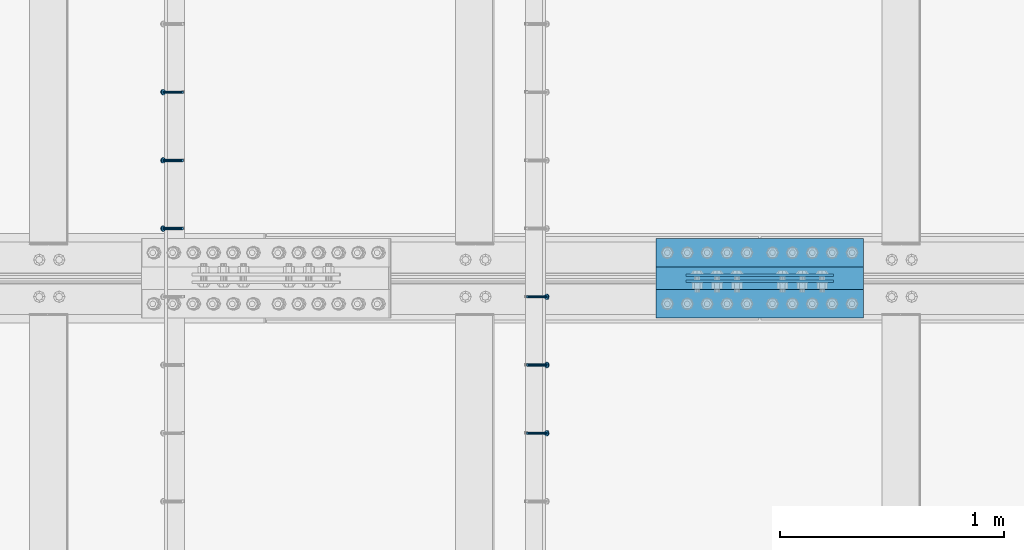
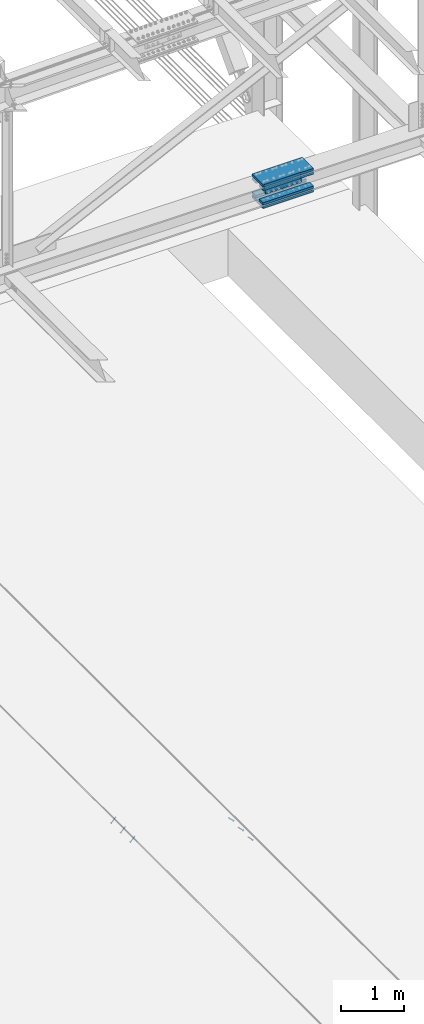
# One storey, part 2470 of 3843: 8 beams, 6 members, 3 elements without a shape of their own.
"""IFC2X3 building model written with IfcOpenShell, lengths in millimetres."""

import ifcopenshell
import ifcopenshell.guid

model = None  # the IFC model being written
_history = None  # IfcOwnerHistory: only IFC2X3 demands one
_inside = {}  # id of a spatial element -> (the spatial element, [elements in it])
_under = {}  # id of a project, library or spatial element -> (it, [spatial elements below it])
_declared = {}  # id of a project -> (the project, [libraries it declares])
_typed = {}  # id of a type object -> (the type object, [elements of that type])
_made_of = {}  # id of a material, layer set ... -> (it, [elements and type objects made of it])


def new_model(schema):
    """Start an empty IFC model of exactly this schema.

    Asked for "IFC4X3", IfcOpenShell would pick the latest addendum, in which some entities
    have other attributes; the version numbers below select the first issue.
    IFC2X3 requires an IfcOwnerHistory on every rooted entity: one is made here for all.
    """
    global model, _history
    if schema == "IFC4X3":
        model = ifcopenshell.file(schema_version=(4, 3, 0, 0))
    else:
        model = ifcopenshell.file(schema=schema)
    _inside.clear()
    _under.clear()
    _declared.clear()
    _typed.clear()
    _made_of.clear()
    _history = None
    if model.schema == "IFC2X3":
        org = make("IfcOrganization", Name="unknown")
        user = make(
            "IfcPersonAndOrganization",
            ThePerson=make("IfcPerson", FamilyName="unknown"),
            TheOrganization=org,
        )
        app = make(
            "IfcApplication",
            ApplicationDeveloper=org,
            Version="unknown",
            ApplicationFullName="unknown",
            ApplicationIdentifier="unknown",
        )
        _history = make(
            "IfcOwnerHistory",
            OwningUser=user,
            OwningApplication=app,
            ChangeAction="ADDED",
            CreationDate=0,
        )
    return model


def make(cls, **values):
    """One entity of the class cls with the attributes given. An attribute that is None is left unset."""
    return model.create_entity(
        cls, **{name: value for name, value in values.items() if value is not None}
    )


def rooted(cls, **values):
    """An entity with a GlobalId (a new one), such as an element, a storey or a relation."""
    return make(cls, GlobalId=ifcopenshell.guid.new(), OwnerHistory=_history, **values)


def si_unit(unit_type, name, prefix=None):
    """IfcSIUnit, for example si_unit("LENGTHUNIT", "METRE", prefix="MILLI")."""
    return make("IfcSIUnit", UnitType=unit_type, Prefix=prefix, Name=name)


def assignment(units):
    """IfcUnitAssignment: the units of a project."""
    return None if units is None else make("IfcUnitAssignment", Units=units)


def point(xyz):
    """IfcCartesianPoint."""
    return None if xyz is None else make("IfcCartesianPoint", Coordinates=xyz)


def direction(xyz):
    """IfcDirection."""
    return None if xyz is None else make("IfcDirection", DirectionRatios=xyz)


def frame(location, z_axis=None, x_axis=None):
    """IfcAxis2Placement3D, a coordinate frame: its origin and axes. An axis left out is left unset."""
    return make(
        "IfcAxis2Placement3D",
        Location=point(location),
        Axis=direction(z_axis),
        RefDirection=direction(x_axis),
    )


def origin_with_axes():
    """The frame at (0, 0, 0) with the z axis (0, 0, 1) and the x axis (1, 0, 0) written out."""
    return frame((0.0, 0.0, 0.0), z_axis=(0.0, 0.0, 1.0), x_axis=(1.0, 0.0, 0.0))


def place(relative_to, where):
    """IfcLocalPlacement: puts the frame where relative to a parent placement (None: the world)."""
    return make(
        "IfcLocalPlacement", PlacementRelTo=relative_to, RelativePlacement=where
    )


def context(
    kind, dimensions, precision=None, world=None, true_north=None, identifier=None
):
    """IfcGeometricRepresentationContext, for example the 3D "Model" context."""
    return make(
        "IfcGeometricRepresentationContext",
        ContextIdentifier=identifier,
        ContextType=kind,
        CoordinateSpaceDimension=dimensions,
        Precision=precision,
        WorldCoordinateSystem=world,
        TrueNorth=true_north,
    )


def subcontext(parent, identifier, kind, view, scale=None):
    """IfcGeometricRepresentationSubContext, for example "Body" below "Model"."""
    return make(
        "IfcGeometricRepresentationSubContext",
        ContextIdentifier=identifier,
        ContextType=kind,
        ParentContext=parent,
        TargetScale=scale,
        TargetView=view,
    )


def project(units=None, contexts=None):
    """IfcProject with its units and contexts."""
    return rooted(
        "IfcProject",
        Name="project",
        RepresentationContexts=contexts,
        UnitsInContext=assignment(units),
    )


def spatial(cls, under=None, at=None, **own):
    """A site, building, storey or space (cls), placed at a placement, below another one or the project."""
    s = rooted(cls, ObjectPlacement=at, **own)
    if under is not None:
        _under.setdefault(under.id(), (under, []))[1].append(s)
    return s


def faces_of(points, faces, orient=None, outer=None):
    """IfcFace entities. A face is a list of loops; a loop is a list of indices into points, from 0.

    orient and outer hold one flag for each loop. By default every Orientation is true, the
    first loop of a face is its IfcFaceOuterBound and the others are IfcFaceBound.
    """
    made = []
    for i, loops in enumerate(faces):
        bounds = []
        for j, loop in enumerate(loops):
            is_outer = j == 0 if outer is None else outer[i][j]
            bounds.append(
                make(
                    "IfcFaceOuterBound" if is_outer else "IfcFaceBound",
                    Bound=make("IfcPolyLoop", Polygon=[points[k] for k in loop]),
                    Orientation=True if orient is None else orient[i][j],
                )
            )
        made.append(make("IfcFace", Bounds=bounds))
    return made


def faceted_brep(points, faces, orient=None, outer=None, voids=None):
    """IfcFacetedBrep: a solid bounded by flat faces; with voids (closed shells), ...WithVoids."""
    shared = [point(p) for p in points]
    hull = make("IfcClosedShell", CfsFaces=faces_of(shared, faces, orient, outer))
    if voids is None:
        return make("IfcFacetedBrep", Outer=hull)
    return make(
        "IfcFacetedBrepWithVoids",
        Outer=hull,
        Voids=[
            make(cls, CfsFaces=faces_of(shared, fs, o, b)) for cls, fs, o, b in voids
        ],
    )


def shape(context_of_items, identifier, shape_type, items):
    """IfcShapeRepresentation: the items that make up one representation, for example the "Body"."""
    return make(
        "IfcShapeRepresentation",
        ContextOfItems=context_of_items,
        RepresentationIdentifier=identifier,
        RepresentationType=shape_type,
        Items=items,
    )


def material(Name=None, Category=None):
    """IfcMaterial."""
    return make("IfcMaterial", Name=Name, Category=Category)


def made_of(thing, what):
    """Note that an element or type object is made of a material, layer set ...; save() writes the relation."""
    if what is not None:
        _made_of.setdefault(what.id(), (what, []))[1].append(thing)
    return thing


def type_object(cls, material=None, **own):
    """A type object (cls), such as IfcWallType, which elements share."""
    return made_of(rooted(cls, **own), material)


def element(
    cls,
    number,
    at=None,
    inside=None,
    cuts=None,
    type_object=None,
    material=None,
    context=None,
    identifier="Body",
    shape_type=None,
    held_by="IfcProductDefinitionShape",
    body=None,
    shapes=None,
    **own,
):
    """One element of the class cls, such as IfcWall. Its Tag is "e" and its number.

    at: its placement. inside: the storey or other place that contains it. cuts: it is an
    opening in that element (IfcRelVoidsElement). A single representation is given by context,
    identifier, shape_type and body (its items); several are given by shapes. held_by: the class
    of the entity that holds the representations. save() writes the other relations.
    """
    e = rooted(cls, Tag="e%d" % number, ObjectPlacement=at, **own)
    if body is not None:
        shapes = [shape(context, identifier, shape_type, body)]
    if shapes is not None:
        e.Representation = make(held_by, Representations=shapes)
    if inside is not None:
        _inside.setdefault(inside.id(), (inside, []))[1].append(e)
    if cuts is not None:
        rooted(
            "IfcRelVoidsElement", RelatingBuildingElement=cuts, RelatedOpeningElement=e
        )
    if type_object is not None:
        _typed.setdefault(type_object.id(), (type_object, []))[1].append(e)
    return made_of(e, material)


def aggregate(whole, parts):
    """IfcRelAggregates: a whole, such as a stair, and the parts it consists of."""
    return rooted("IfcRelAggregates", RelatingObject=whole, RelatedObjects=parts)


def save(model, path):
    """Write the relations noted so far, then the file.

    IfcRelAggregates (storeys below a building ...), IfcRelContainedInSpatialStructure (elements
    in a storey), IfcRelDefinesByType, IfcRelAssociatesMaterial and IfcRelDeclares: one each for
    every whole, place, type object, material and project.
    """
    for whole, parts in _under.values():
        aggregate(whole, parts)
    for where, things in _inside.values():
        rooted(
            "IfcRelContainedInSpatialStructure",
            RelatedElements=things,
            RelatingStructure=where,
        )
    for kind, things in _typed.values():
        rooted("IfcRelDefinesByType", RelatedObjects=things, RelatingType=kind)
    for what, things in _made_of.values():
        rooted("IfcRelAssociatesMaterial", RelatedObjects=things, RelatingMaterial=what)
    for by, libraries in _declared.values():
        rooted("IfcRelDeclares", RelatingContext=by, RelatedDefinitions=libraries)
    model.write(path)


model = new_model("IFC2X3")

# Units and contexts
model_context = context("Model", 3, precision=1e-05, world=origin_with_axes())
body_context = subcontext(model_context, "Body", "Model", "MODEL_VIEW")
ifc_project = project(units=[si_unit("LENGTHUNIT", "METRE", prefix="MILLI"), si_unit("AREAUNIT", "SQUARE_METRE"), si_unit("VOLUMEUNIT", "CUBIC_METRE"), si_unit("MASSUNIT", "GRAM", prefix="KILO"), si_unit("TIMEUNIT", "SECOND"), si_unit("PLANEANGLEUNIT", "RADIAN"), si_unit("SOLIDANGLEUNIT", "STERADIAN"), si_unit("THERMODYNAMICTEMPERATUREUNIT", "DEGREE_CELSIUS"), si_unit("LUMINOUSINTENSITYUNIT", "LUMEN")], contexts=[model_context])

# Site, building, storey
site_placement = place(None, origin_with_axes())
site = spatial("IfcSite", under=ifc_project, at=site_placement, CompositionType="ELEMENT")
building_placement = place(site_placement, origin_with_axes())
building = spatial("IfcBuilding", under=site, at=building_placement, Name="Undefined", CompositionType="ELEMENT")
storey_placement = place(building_placement, origin_with_axes())
storey = spatial("IfcBuildingStorey", under=building, at=storey_placement, Name="Undefined", CompositionType="ELEMENT", Elevation=0.0)

# Assembly, members
assembly_1_placement = place(storey_placement, origin_with_axes())
assembly_1 = element("IfcElementAssembly", 1, at=assembly_1_placement, inside=storey, Name="EMBED_ANGLE", AssemblyPlace="NOTDEFINED", PredefinedType="RIGID_FRAME")
ifc_material_1 = material(Name="STEEL/A108")
member_type = type_object("IfcMemberType", PredefinedType="NOTDEFINED")
member_1_placement = place(assembly_1_placement, frame((66677.3495, 74936.2227092285, 30446.6625), z_axis=(0.0, 1.0, 0.0), x_axis=(0.707106781186548, 0.0, -0.707106781186548)))
member_1 = element("IfcMember", 2, at=member_1_placement, type_object=member_type, material=ifc_material_1, Name="HEADED STUD ANCHOR", context=body_context, shape_type="Brep", body=[
    faceted_brep([(7.27595761418343e-12, -3.18000006675175, 5.5), (0.0, -5.49999999998363, 3.1800000667572), (118.110000000976, -5.49999999999091, 3.1800000667572), (118.110000000983, -3.18000006675175, 5.5), (0.0, -6.3499999046162, 0.0), (118.110000000968, -6.34999990461256, 0.0), (0.0, -5.49999999998363, -3.1800000667572), (118.110000000976, -5.49999999999091, -3.1800000667572), (7.27595761418343e-12, -3.18000006675175, -5.5), (118.110000000983, -3.18000006675175, -5.5), (7.27595761418343e-12, -1.81898940354586e-12, -6.34999990463257), (118.110000000968, -1.81898940354586e-12, -6.34999990463257), (0.0, 3.18000006675175, -5.5), (118.110000000968, 3.18000006674811, -5.5), (7.27595761418343e-12, 5.49999999998363, -3.1800000667572), (118.110000000983, 5.49999999998363, -3.1800000667572), (7.27595761418343e-12, 6.3499999046162, 0.0), (118.110000000976, 6.34999990461256, 0.0), (7.27595761418343e-12, 5.49999999998363, 3.1800000667572), (118.110000000983, 5.49999999998363, 3.1800000667572), (0.0, 3.18000006675175, 5.5), (118.110000000968, 3.18000006674811, 5.5), (7.27595761418343e-12, -1.81898940354586e-12, 6.34999990463257), (118.110000000968, -1.81898940354586e-12, 6.34999990463257), (120.650000000991, -10.9899997710909, 6.34999990463257), (120.650000000998, -6.34000015257152, 10.9899997711182), (120.650000000991, -12.6999998092379, 0.0), (120.650000000991, -10.9899997710909, -6.34999990463257), (120.650000000998, -6.34000015257152, -10.9899997711182), (120.650000000991, -1.81898940354586e-12, -12.6899995803833), (120.650000000991, 6.34000015257152, -10.9899997711182), (120.650000000998, 10.9899997710909, -6.34999990463257), (120.650000000991, 12.6999998092342, 0.0), (120.650000000998, 10.9899997710909, 6.34999990463257), (120.650000000991, 6.34000015257152, 10.9899997711182), (120.650000000991, -1.81898940354586e-12, 12.6899995803833), (127.000000001048, -10.9899997710945, 6.34999990463257), (127.000000001048, -6.34000015257152, 10.9899997711182), (127.000000001048, -12.6999998092342, 0.0), (127.000000001048, -10.9899997710945, -6.34999990463257), (127.000000001048, -6.34000015257152, -10.9899997711182), (127.000000001048, 1.81898940354586e-12, -12.6899995803833), (127.000000001048, 6.34000015256788, -10.9899997711182), (127.000000001048, 10.9899997710909, -6.34999990463257), (127.000000001048, 12.6999998092379, 0.0), (127.000000001048, 10.9899997710909, 6.34999990463257), (127.000000001048, 6.34000015256788, 10.9899997711182), (127.000000001048, 1.81898940354586e-12, 12.6899995803833)], [[[0, 1, 2, 3]], [[1, 4, 5, 2]], [[4, 6, 7, 5]], [[6, 8, 9, 7]], [[8, 10, 11, 9]], [[10, 12, 13, 11]], [[12, 14, 15, 13]], [[14, 16, 17, 15]], [[16, 18, 19, 17]], [[18, 20, 21, 19]], [[20, 22, 23, 21]], [[22, 0, 3, 23]], [[22, 20, 18, 16, 14, 12, 10, 8, 6, 4, 1, 0]], [[3, 2, 24, 25]], [[2, 5, 26, 24]], [[5, 7, 27, 26]], [[7, 9, 28, 27]], [[9, 11, 29, 28]], [[11, 13, 30, 29]], [[13, 15, 31, 30]], [[15, 17, 32, 31]], [[17, 19, 33, 32]], [[19, 21, 34, 33]], [[21, 23, 35, 34]], [[23, 3, 25, 35]], [[25, 24, 36, 37]], [[24, 26, 38, 36]], [[26, 27, 39, 38]], [[27, 28, 40, 39]], [[28, 29, 41, 40]], [[29, 30, 42, 41]], [[30, 31, 43, 42]], [[31, 32, 44, 43]], [[32, 33, 45, 44]], [[33, 34, 46, 45]], [[34, 35, 47, 46]], [[35, 25, 37, 47]], [[38, 39, 40, 41, 42, 43, 44, 45, 46, 47, 37, 36]]]),
])
member_2_placement = place(assembly_1_placement, frame((66677.3495, 75241.0227092285, 30446.6625), z_axis=(0.0, 1.0, 0.0), x_axis=(0.707106781186548, 0.0, -0.707106781186548)))
member_2 = element("IfcMember", 3, at=member_2_placement, type_object=member_type, material=ifc_material_1, Name="HEADED STUD ANCHOR", context=body_context, shape_type="Brep", body=[
    faceted_brep([(7.27595761418343e-12, -3.18000006675175, 5.5), (0.0, -5.49999999998363, 3.1800000667572), (118.110000000976, -5.49999999999091, 3.1800000667572), (118.110000000983, -3.18000006675175, 5.5), (0.0, -6.3499999046162, 0.0), (118.110000000968, -6.34999990461256, 0.0), (0.0, -5.49999999998363, -3.1800000667572), (118.110000000976, -5.49999999999091, -3.1800000667572), (7.27595761418343e-12, -3.18000006675175, -5.5), (118.110000000983, -3.18000006675175, -5.5), (7.27595761418343e-12, -1.81898940354586e-12, -6.34999990463257), (118.110000000968, -1.81898940354586e-12, -6.34999990463257), (0.0, 3.18000006675175, -5.5), (118.110000000968, 3.18000006674811, -5.5), (7.27595761418343e-12, 5.49999999998363, -3.1800000667572), (118.110000000983, 5.49999999998363, -3.1800000667572), (7.27595761418343e-12, 6.3499999046162, 0.0), (118.110000000976, 6.34999990461256, 0.0), (7.27595761418343e-12, 5.49999999998363, 3.1800000667572), (118.110000000983, 5.49999999998363, 3.1800000667572), (0.0, 3.18000006675175, 5.5), (118.110000000968, 3.18000006674811, 5.5), (7.27595761418343e-12, -1.81898940354586e-12, 6.34999990463257), (118.110000000968, -1.81898940354586e-12, 6.34999990463257), (120.650000000991, -10.9899997710909, 6.34999990463257), (120.650000000998, -6.34000015257152, 10.9899997711182), (120.650000000991, -12.6999998092379, 0.0), (120.650000000991, -10.9899997710909, -6.34999990463257), (120.650000000998, -6.34000015257152, -10.9899997711182), (120.650000000991, -1.81898940354586e-12, -12.6899995803833), (120.650000000991, 6.34000015257152, -10.9899997711182), (120.650000000998, 10.9899997710909, -6.34999990463257), (120.650000000991, 12.6999998092342, 0.0), (120.650000000998, 10.9899997710909, 6.34999990463257), (120.650000000991, 6.34000015257152, 10.9899997711182), (120.650000000991, -1.81898940354586e-12, 12.6899995803833), (127.000000001048, -10.9899997710945, 6.34999990463257), (127.000000001048, -6.34000015257152, 10.9899997711182), (127.000000001048, -12.6999998092342, 0.0), (127.000000001048, -10.9899997710945, -6.34999990463257), (127.000000001048, -6.34000015257152, -10.9899997711182), (127.000000001048, 1.81898940354586e-12, -12.6899995803833), (127.000000001048, 6.34000015256788, -10.9899997711182), (127.000000001048, 10.9899997710909, -6.34999990463257), (127.000000001048, 12.6999998092379, 0.0), (127.000000001048, 10.9899997710909, 6.34999990463257), (127.000000001048, 6.34000015256788, 10.9899997711182), (127.000000001048, 1.81898940354586e-12, 12.6899995803833)], [[[0, 1, 2, 3]], [[1, 4, 5, 2]], [[4, 6, 7, 5]], [[6, 8, 9, 7]], [[8, 10, 11, 9]], [[10, 12, 13, 11]], [[12, 14, 15, 13]], [[14, 16, 17, 15]], [[16, 18, 19, 17]], [[18, 20, 21, 19]], [[20, 22, 23, 21]], [[22, 0, 3, 23]], [[22, 20, 18, 16, 14, 12, 10, 8, 6, 4, 1, 0]], [[3, 2, 24, 25]], [[2, 5, 26, 24]], [[5, 7, 27, 26]], [[7, 9, 28, 27]], [[9, 11, 29, 28]], [[11, 13, 30, 29]], [[13, 15, 31, 30]], [[15, 17, 32, 31]], [[17, 19, 33, 32]], [[19, 21, 34, 33]], [[21, 23, 35, 34]], [[23, 3, 25, 35]], [[25, 24, 36, 37]], [[24, 26, 38, 36]], [[26, 27, 39, 38]], [[27, 28, 40, 39]], [[28, 29, 41, 40]], [[29, 30, 42, 41]], [[30, 31, 43, 42]], [[31, 32, 44, 43]], [[32, 33, 45, 44]], [[33, 34, 46, 45]], [[34, 35, 47, 46]], [[35, 25, 37, 47]], [[38, 39, 40, 41, 42, 43, 44, 45, 46, 47, 37, 36]]]),
])
member_3_placement = place(assembly_1_placement, frame((66677.3495, 75545.8227092285, 30446.6625), z_axis=(0.0, 1.0, 0.0), x_axis=(0.707106781186548, 0.0, -0.707106781186548)))
member_3 = element("IfcMember", 4, at=member_3_placement, type_object=member_type, material=ifc_material_1, Name="HEADED STUD ANCHOR", context=body_context, shape_type="Brep", body=[
    faceted_brep([(7.27595761418343e-12, -3.18000006675175, 5.5), (0.0, -5.49999999998363, 3.1800000667572), (118.110000000976, -5.49999999999091, 3.1800000667572), (118.110000000983, -3.18000006675175, 5.5), (0.0, -6.3499999046162, 0.0), (118.110000000968, -6.34999990461256, 0.0), (0.0, -5.49999999998363, -3.1800000667572), (118.110000000976, -5.49999999999091, -3.1800000667572), (7.27595761418343e-12, -3.18000006675175, -5.5), (118.110000000983, -3.18000006675175, -5.5), (7.27595761418343e-12, -1.81898940354586e-12, -6.34999990463257), (118.110000000968, -1.81898940354586e-12, -6.34999990463257), (0.0, 3.18000006675175, -5.5), (118.110000000968, 3.18000006674811, -5.5), (7.27595761418343e-12, 5.49999999998363, -3.1800000667572), (118.110000000983, 5.49999999998363, -3.1800000667572), (7.27595761418343e-12, 6.3499999046162, 0.0), (118.110000000976, 6.34999990461256, 0.0), (7.27595761418343e-12, 5.49999999998363, 3.1800000667572), (118.110000000983, 5.49999999998363, 3.1800000667572), (0.0, 3.18000006675175, 5.5), (118.110000000968, 3.18000006674811, 5.5), (7.27595761418343e-12, -1.81898940354586e-12, 6.34999990463257), (118.110000000968, -1.81898940354586e-12, 6.34999990463257), (120.650000000991, -10.9899997710909, 6.34999990463257), (120.650000000998, -6.34000015257152, 10.9899997711182), (120.650000000991, -12.6999998092379, 0.0), (120.650000000991, -10.9899997710909, -6.34999990463257), (120.650000000998, -6.34000015257152, -10.9899997711182), (120.650000000991, -1.81898940354586e-12, -12.6899995803833), (120.650000000991, 6.34000015257152, -10.9899997711182), (120.650000000998, 10.9899997710909, -6.34999990463257), (120.650000000991, 12.6999998092342, 0.0), (120.650000000998, 10.9899997710909, 6.34999990463257), (120.650000000991, 6.34000015257152, 10.9899997711182), (120.650000000991, -1.81898940354586e-12, 12.6899995803833), (127.000000001048, -10.9899997710945, 6.34999990463257), (127.000000001048, -6.34000015257152, 10.9899997711182), (127.000000001048, -12.6999998092342, 0.0), (127.000000001048, -10.9899997710945, -6.34999990463257), (127.000000001048, -6.34000015257152, -10.9899997711182), (127.000000001048, 1.81898940354586e-12, -12.6899995803833), (127.000000001048, 6.34000015256788, -10.9899997711182), (127.000000001048, 10.9899997710909, -6.34999990463257), (127.000000001048, 12.6999998092379, 0.0), (127.000000001048, 10.9899997710909, 6.34999990463257), (127.000000001048, 6.34000015256788, 10.9899997711182), (127.000000001048, 1.81898940354586e-12, 12.6899995803833)], [[[0, 1, 2, 3]], [[1, 4, 5, 2]], [[4, 6, 7, 5]], [[6, 8, 9, 7]], [[8, 10, 11, 9]], [[10, 12, 13, 11]], [[12, 14, 15, 13]], [[14, 16, 17, 15]], [[16, 18, 19, 17]], [[18, 20, 21, 19]], [[20, 22, 23, 21]], [[22, 0, 3, 23]], [[22, 20, 18, 16, 14, 12, 10, 8, 6, 4, 1, 0]], [[3, 2, 24, 25]], [[2, 5, 26, 24]], [[5, 7, 27, 26]], [[7, 9, 28, 27]], [[9, 11, 29, 28]], [[11, 13, 30, 29]], [[13, 15, 31, 30]], [[15, 17, 32, 31]], [[17, 19, 33, 32]], [[19, 21, 34, 33]], [[21, 23, 35, 34]], [[23, 3, 25, 35]], [[25, 24, 36, 37]], [[24, 26, 38, 36]], [[26, 27, 39, 38]], [[27, 28, 40, 39]], [[28, 29, 41, 40]], [[29, 30, 42, 41]], [[30, 31, 43, 42]], [[31, 32, 44, 43]], [[32, 33, 45, 44]], [[33, 34, 46, 45]], [[34, 35, 47, 46]], [[35, 25, 37, 47]], [[38, 39, 40, 41, 42, 43, 44, 45, 46, 47, 37, 36]]]),
])
aggregate(assembly_1, [member_1, member_2, member_3])

assembly_2_placement = place(storey_placement, origin_with_axes())
assembly_2 = element("IfcElementAssembly", 5, at=assembly_2_placement, inside=storey, Name="EMBED_ANGLE", AssemblyPlace="NOTDEFINED", PredefinedType="RIGID_FRAME")
member_4_placement = place(assembly_2_placement, frame((65137.5380556641, 75850.6227092285, 30446.6625), z_axis=(0.0, 1.0, 0.0), x_axis=(-0.707106781186548, 0.0, -0.707106781186548)))
member_4 = element("IfcMember", 6, at=member_4_placement, type_object=member_type, material=ifc_material_1, Name="HEADED STUD ANCHOR", context=body_context, shape_type="Brep", body=[
    faceted_brep([(7.27595761418343e-12, -3.18000006675175, 5.5), (0.0, -5.49999999998363, 3.1800000667572), (118.110000000976, -5.49999999999091, 3.1800000667572), (118.110000000983, -3.18000006675175, 5.5), (0.0, -6.3499999046162, 0.0), (118.110000000968, -6.34999990461256, 0.0), (0.0, -5.49999999998363, -3.1800000667572), (118.110000000976, -5.49999999999091, -3.1800000667572), (7.27595761418343e-12, -3.18000006675175, -5.5), (118.110000000983, -3.18000006675175, -5.5), (7.27595761418343e-12, -1.81898940354586e-12, -6.34999990463257), (118.110000000968, -1.81898940354586e-12, -6.34999990463257), (0.0, 3.18000006675175, -5.5), (118.110000000968, 3.18000006674811, -5.5), (7.27595761418343e-12, 5.49999999998363, -3.1800000667572), (118.110000000983, 5.49999999998363, -3.1800000667572), (7.27595761418343e-12, 6.3499999046162, 0.0), (118.110000000976, 6.34999990461256, 0.0), (7.27595761418343e-12, 5.49999999998363, 3.1800000667572), (118.110000000983, 5.49999999998363, 3.1800000667572), (0.0, 3.18000006675175, 5.5), (118.110000000968, 3.18000006674811, 5.5), (7.27595761418343e-12, -1.81898940354586e-12, 6.34999990463257), (118.110000000968, -1.81898940354586e-12, 6.34999990463257), (120.650000000991, -10.9899997710909, 6.34999990463257), (120.650000000998, -6.34000015257152, 10.9899997711182), (120.650000000991, -12.6999998092379, 0.0), (120.650000000991, -10.9899997710909, -6.34999990463257), (120.650000000998, -6.34000015257152, -10.9899997711182), (120.650000000991, -1.81898940354586e-12, -12.6899995803833), (120.650000000991, 6.34000015257152, -10.9899997711182), (120.650000000998, 10.9899997710909, -6.34999990463257), (120.650000000991, 12.6999998092342, 0.0), (120.650000000998, 10.9899997710909, 6.34999990463257), (120.650000000991, 6.34000015257152, 10.9899997711182), (120.650000000991, -1.81898940354586e-12, 12.6899995803833), (127.000000001048, -10.9899997710945, 6.34999990463257), (127.000000001048, -6.34000015257152, 10.9899997711182), (127.000000001048, -12.6999998092342, 0.0), (127.000000001048, -10.9899997710945, -6.34999990463257), (127.000000001048, -6.34000015257152, -10.9899997711182), (127.000000001048, 1.81898940354586e-12, -12.6899995803833), (127.000000001048, 6.34000015256788, -10.9899997711182), (127.000000001048, 10.9899997710909, -6.34999990463257), (127.000000001048, 12.6999998092379, 0.0), (127.000000001048, 10.9899997710909, 6.34999990463257), (127.000000001048, 6.34000015256788, 10.9899997711182), (127.000000001048, 1.81898940354586e-12, 12.6899995803833)], [[[0, 1, 2, 3]], [[1, 4, 5, 2]], [[4, 6, 7, 5]], [[6, 8, 9, 7]], [[8, 10, 11, 9]], [[10, 12, 13, 11]], [[12, 14, 15, 13]], [[14, 16, 17, 15]], [[16, 18, 19, 17]], [[18, 20, 21, 19]], [[20, 22, 23, 21]], [[22, 0, 3, 23]], [[22, 20, 18, 16, 14, 12, 10, 8, 6, 4, 1, 0]], [[3, 2, 24, 25]], [[2, 5, 26, 24]], [[5, 7, 27, 26]], [[7, 9, 28, 27]], [[9, 11, 29, 28]], [[11, 13, 30, 29]], [[13, 15, 31, 30]], [[15, 17, 32, 31]], [[17, 19, 33, 32]], [[19, 21, 34, 33]], [[21, 23, 35, 34]], [[23, 3, 25, 35]], [[25, 24, 36, 37]], [[24, 26, 38, 36]], [[26, 27, 39, 38]], [[27, 28, 40, 39]], [[28, 29, 41, 40]], [[29, 30, 42, 41]], [[30, 31, 43, 42]], [[31, 32, 44, 43]], [[32, 33, 45, 44]], [[33, 34, 46, 45]], [[34, 35, 47, 46]], [[35, 25, 37, 47]], [[38, 39, 40, 41, 42, 43, 44, 45, 46, 47, 37, 36]]]),
])
member_5_placement = place(assembly_2_placement, frame((65137.5380556641, 76155.4227092285, 30446.6625), z_axis=(0.0, 1.0, 0.0), x_axis=(-0.707106781186548, 0.0, -0.707106781186548)))
member_5 = element("IfcMember", 7, at=member_5_placement, type_object=member_type, material=ifc_material_1, Name="HEADED STUD ANCHOR", context=body_context, shape_type="Brep", body=[
    faceted_brep([(7.27595761418343e-12, -3.18000006675175, 5.5), (0.0, -5.49999999998363, 3.1800000667572), (118.110000000976, -5.49999999999091, 3.1800000667572), (118.110000000983, -3.18000006675175, 5.5), (0.0, -6.3499999046162, 0.0), (118.110000000968, -6.34999990461256, 0.0), (0.0, -5.49999999998363, -3.1800000667572), (118.110000000976, -5.49999999999091, -3.1800000667572), (7.27595761418343e-12, -3.18000006675175, -5.5), (118.110000000983, -3.18000006675175, -5.5), (7.27595761418343e-12, -1.81898940354586e-12, -6.34999990463257), (118.110000000968, -1.81898940354586e-12, -6.34999990463257), (0.0, 3.18000006675175, -5.5), (118.110000000968, 3.18000006674811, -5.5), (7.27595761418343e-12, 5.49999999998363, -3.1800000667572), (118.110000000983, 5.49999999998363, -3.1800000667572), (7.27595761418343e-12, 6.3499999046162, 0.0), (118.110000000976, 6.34999990461256, 0.0), (7.27595761418343e-12, 5.49999999998363, 3.1800000667572), (118.110000000983, 5.49999999998363, 3.1800000667572), (0.0, 3.18000006675175, 5.5), (118.110000000968, 3.18000006674811, 5.5), (7.27595761418343e-12, -1.81898940354586e-12, 6.34999990463257), (118.110000000968, -1.81898940354586e-12, 6.34999990463257), (120.650000000991, -10.9899997710909, 6.34999990463257), (120.650000000998, -6.34000015257152, 10.9899997711182), (120.650000000991, -12.6999998092379, 0.0), (120.650000000991, -10.9899997710909, -6.34999990463257), (120.650000000998, -6.34000015257152, -10.9899997711182), (120.650000000991, -1.81898940354586e-12, -12.6899995803833), (120.650000000991, 6.34000015257152, -10.9899997711182), (120.650000000998, 10.9899997710909, -6.34999990463257), (120.650000000991, 12.6999998092342, 0.0), (120.650000000998, 10.9899997710909, 6.34999990463257), (120.650000000991, 6.34000015257152, 10.9899997711182), (120.650000000991, -1.81898940354586e-12, 12.6899995803833), (127.000000001048, -10.9899997710945, 6.34999990463257), (127.000000001048, -6.34000015257152, 10.9899997711182), (127.000000001048, -12.6999998092342, 0.0), (127.000000001048, -10.9899997710945, -6.34999990463257), (127.000000001048, -6.34000015257152, -10.9899997711182), (127.000000001048, 1.81898940354586e-12, -12.6899995803833), (127.000000001048, 6.34000015256788, -10.9899997711182), (127.000000001048, 10.9899997710909, -6.34999990463257), (127.000000001048, 12.6999998092379, 0.0), (127.000000001048, 10.9899997710909, 6.34999990463257), (127.000000001048, 6.34000015256788, 10.9899997711182), (127.000000001048, 1.81898940354586e-12, 12.6899995803833)], [[[0, 1, 2, 3]], [[1, 4, 5, 2]], [[4, 6, 7, 5]], [[6, 8, 9, 7]], [[8, 10, 11, 9]], [[10, 12, 13, 11]], [[12, 14, 15, 13]], [[14, 16, 17, 15]], [[16, 18, 19, 17]], [[18, 20, 21, 19]], [[20, 22, 23, 21]], [[22, 0, 3, 23]], [[22, 20, 18, 16, 14, 12, 10, 8, 6, 4, 1, 0]], [[3, 2, 24, 25]], [[2, 5, 26, 24]], [[5, 7, 27, 26]], [[7, 9, 28, 27]], [[9, 11, 29, 28]], [[11, 13, 30, 29]], [[13, 15, 31, 30]], [[15, 17, 32, 31]], [[17, 19, 33, 32]], [[19, 21, 34, 33]], [[21, 23, 35, 34]], [[23, 3, 25, 35]], [[25, 24, 36, 37]], [[24, 26, 38, 36]], [[26, 27, 39, 38]], [[27, 28, 40, 39]], [[28, 29, 41, 40]], [[29, 30, 42, 41]], [[30, 31, 43, 42]], [[31, 32, 44, 43]], [[32, 33, 45, 44]], [[33, 34, 46, 45]], [[34, 35, 47, 46]], [[35, 25, 37, 47]], [[38, 39, 40, 41, 42, 43, 44, 45, 46, 47, 37, 36]]]),
])
member_6_placement = place(assembly_2_placement, frame((65137.5380556641, 76460.2227092285, 30446.6625), z_axis=(0.0, 1.0, 0.0), x_axis=(-0.707106781186548, 0.0, -0.707106781186548)))
member_6 = element("IfcMember", 8, at=member_6_placement, type_object=member_type, material=ifc_material_1, Name="HEADED STUD ANCHOR", context=body_context, shape_type="Brep", body=[
    faceted_brep([(7.27595761418343e-12, -3.18000006675175, 5.5), (0.0, -5.49999999998363, 3.1800000667572), (118.110000000976, -5.49999999999091, 3.1800000667572), (118.110000000983, -3.18000006675175, 5.5), (0.0, -6.3499999046162, 0.0), (118.110000000968, -6.34999990461256, 0.0), (0.0, -5.49999999998363, -3.1800000667572), (118.110000000976, -5.49999999999091, -3.1800000667572), (7.27595761418343e-12, -3.18000006675175, -5.5), (118.110000000983, -3.18000006675175, -5.5), (7.27595761418343e-12, -1.81898940354586e-12, -6.34999990463257), (118.110000000968, -1.81898940354586e-12, -6.34999990463257), (0.0, 3.18000006675175, -5.5), (118.110000000968, 3.18000006674811, -5.5), (7.27595761418343e-12, 5.49999999998363, -3.1800000667572), (118.110000000983, 5.49999999998363, -3.1800000667572), (7.27595761418343e-12, 6.3499999046162, 0.0), (118.110000000976, 6.34999990461256, 0.0), (7.27595761418343e-12, 5.49999999998363, 3.1800000667572), (118.110000000983, 5.49999999998363, 3.1800000667572), (0.0, 3.18000006675175, 5.5), (118.110000000968, 3.18000006674811, 5.5), (7.27595761418343e-12, -1.81898940354586e-12, 6.34999990463257), (118.110000000968, -1.81898940354586e-12, 6.34999990463257), (120.650000000991, -10.9899997710909, 6.34999990463257), (120.650000000998, -6.34000015257152, 10.9899997711182), (120.650000000991, -12.6999998092379, 0.0), (120.650000000991, -10.9899997710909, -6.34999990463257), (120.650000000998, -6.34000015257152, -10.9899997711182), (120.650000000991, -1.81898940354586e-12, -12.6899995803833), (120.650000000991, 6.34000015257152, -10.9899997711182), (120.650000000998, 10.9899997710909, -6.34999990463257), (120.650000000991, 12.6999998092342, 0.0), (120.650000000998, 10.9899997710909, 6.34999990463257), (120.650000000991, 6.34000015257152, 10.9899997711182), (120.650000000991, -1.81898940354586e-12, 12.6899995803833), (127.000000001048, -10.9899997710945, 6.34999990463257), (127.000000001048, -6.34000015257152, 10.9899997711182), (127.000000001048, -12.6999998092342, 0.0), (127.000000001048, -10.9899997710945, -6.34999990463257), (127.000000001048, -6.34000015257152, -10.9899997711182), (127.000000001048, 1.81898940354586e-12, -12.6899995803833), (127.000000001048, 6.34000015256788, -10.9899997711182), (127.000000001048, 10.9899997710909, -6.34999990463257), (127.000000001048, 12.6999998092379, 0.0), (127.000000001048, 10.9899997710909, 6.34999990463257), (127.000000001048, 6.34000015256788, 10.9899997711182), (127.000000001048, 1.81898940354586e-12, 12.6899995803833)], [[[0, 1, 2, 3]], [[1, 4, 5, 2]], [[4, 6, 7, 5]], [[6, 8, 9, 7]], [[8, 10, 11, 9]], [[10, 12, 13, 11]], [[12, 14, 15, 13]], [[14, 16, 17, 15]], [[16, 18, 19, 17]], [[18, 20, 21, 19]], [[20, 22, 23, 21]], [[22, 0, 3, 23]], [[22, 20, 18, 16, 14, 12, 10, 8, 6, 4, 1, 0]], [[3, 2, 24, 25]], [[2, 5, 26, 24]], [[5, 7, 27, 26]], [[7, 9, 28, 27]], [[9, 11, 29, 28]], [[11, 13, 30, 29]], [[13, 15, 31, 30]], [[15, 17, 32, 31]], [[17, 19, 33, 32]], [[19, 21, 34, 33]], [[21, 23, 35, 34]], [[23, 3, 25, 35]], [[25, 24, 36, 37]], [[24, 26, 38, 36]], [[26, 27, 39, 38]], [[27, 28, 40, 39]], [[28, 29, 41, 40]], [[29, 30, 42, 41]], [[30, 31, 43, 42]], [[31, 32, 44, 43]], [[32, 33, 45, 44]], [[33, 34, 46, 45]], [[34, 35, 47, 46]], [[35, 25, 37, 47]], [[38, 39, 40, 41, 42, 43, 44, 45, 46, 47, 37, 36]]]),
])
aggregate(assembly_2, [member_4, member_5, member_6])

# Assembly, beams
assembly_3_placement = place(storey_placement, origin_with_axes())
assembly_3 = element("IfcElementAssembly", 9, at=assembly_3_placement, inside=storey, Name="BEAM", AssemblyPlace="NOTDEFINED", PredefinedType="RIGID_FRAME")
ifc_material_2 = material(Name="STEEL/A572-50")
beam_type_1 = type_object("IfcBeamType", PredefinedType="NOTDEFINED")
beam_1_placement = place(assembly_3_placement, frame((68046.5999099196, 75641.99375, 42327.3761540472), z_axis=(4.12900000083026e-05, 0.0, 0.999999999147568), x_axis=(-0.999999999147568, 0.0, 4.12900000034299e-05)))
beam_1 = element("IfcBeam", 10, at=beam_1_placement, type_object=beam_type_1, material=ifc_material_2, Name="PLATE", context=body_context, shape_type="Brep", body=[
    faceted_brep([(1.45519152283669e-11, 6.35000000000582, -88.8999999998996), (0.0, 6.34999999999854, 88.9000015258789), (660.399999982677, 6.35000000000582, 88.8999999999651), (660.399999982707, 6.35000000000582, -88.8999999998268), (0.0, -6.34999999999854, 88.9000015258789), (660.399999982677, -6.35000000000582, 88.8999999999651), (1.45519152283669e-11, -6.35000000000582, -88.8999999998996), (660.399999982707, -6.35000000000582, -88.8999999998268)], [[[0, 1, 2, 3]], [[1, 4, 5, 2]], [[4, 6, 7, 5]], [[6, 0, 3, 7]], [[5, 7, 3, 2]], [[6, 4, 1, 0]]]),
])
beam_2_placement = place(assembly_3_placement, frame((68046.5999099196, 75615.00625, 42327.3761540472), z_axis=(4.12900000083026e-05, 0.0, 0.999999999147568), x_axis=(-0.999999999147568, 0.0, 4.12900000034299e-05)))
beam_2 = element("IfcBeam", 11, at=beam_2_placement, type_object=beam_type_1, material=ifc_material_2, Name="PLATE", context=body_context, shape_type="Brep", body=[
    faceted_brep([(1.45519152283669e-11, 6.35000000000582, -88.8999999998996), (0.0, 6.34999999999854, 88.9000015258789), (660.399999982677, 6.35000000000582, 88.8999999999651), (660.399999982707, 6.35000000000582, -88.8999999998268), (0.0, -6.34999999999854, 88.9000015258789), (660.399999982677, -6.35000000000582, 88.8999999999651), (1.45519152283669e-11, -6.35000000000582, -88.8999999998996), (660.399999982707, -6.35000000000582, -88.8999999998268)], [[[0, 1, 2, 3]], [[1, 4, 5, 2]], [[4, 6, 7, 5]], [[6, 0, 3, 7]], [[5, 7, 3, 2]], [[6, 4, 1, 0]]]),
])
beam_type_2 = type_object("IfcBeamType", PredefinedType="NOTDEFINED")
beam_3_placement = place(assembly_3_placement, frame((68179.9584694419, 75628.5, 42533.744803246), z_axis=(0.0, 1.0, 0.0), x_axis=(-0.999999999147568, 0.0, 4.12900000034299e-05)))
beam_3 = element("IfcBeam", 12, at=beam_3_placement, type_object=beam_type_2, material=ifc_material_2, Name="PLATE", context=body_context, shape_type="Brep", body=[
    faceted_brep([(0.0, 22.2249999999767, -177.800000000003), (0.0, 22.2249999999767, 177.800000000003), (927.099999958984, 22.2250000000859, 177.800000000003), (927.099999958984, 22.2250000000859, -177.800000000003), (0.0, -22.2249999999694, 177.800000000003), (927.099999958984, -22.2249999998749, 177.800000000003), (0.0, -22.2249999999694, -177.800000000003), (927.099999958984, -22.2249999998749, -177.800000000003)], [[[0, 1, 2, 3]], [[1, 4, 5, 2]], [[4, 6, 7, 5]], [[6, 0, 3, 7]], [[5, 7, 3, 2]], [[6, 4, 1, 0]]]),
])
beam_4_placement = place(assembly_3_placement, frame((68179.9453867056, 75628.5, 42120.9250514416), z_axis=(0.0, 1.0, 0.0), x_axis=(-0.999999999147568, 0.0, 4.12900000034299e-05)))
beam_4 = element("IfcBeam", 13, at=beam_4_placement, type_object=beam_type_2, material=ifc_material_2, Name="PLATE", context=body_context, shape_type="Brep", body=[
    faceted_brep([(0.0, 22.2249999999767, -177.800000000003), (0.0, 22.2249999999767, 177.800000000003), (927.099999958984, 22.2250000000859, 177.800000000003), (927.099999958984, 22.2250000000859, -177.800000000003), (0.0, -22.2249999999694, 177.800000000003), (927.099999958984, -22.2249999998749, 177.800000000003), (0.0, -22.2249999999694, -177.800000000003), (927.099999958984, -22.2249999998749, -177.800000000003)], [[[0, 1, 2, 3]], [[1, 4, 5, 2]], [[4, 6, 7, 5]], [[6, 0, 3, 7]], [[5, 7, 3, 2]], [[6, 4, 1, 0]]]),
])
beam_type_3 = type_object("IfcBeamType", PredefinedType="NOTDEFINED")
beam_5_placement = place(assembly_3_placement, frame((67252.8441797173, 75742.8, 42189.2367334503), z_axis=(0.0, 1.0, 0.0), x_axis=(0.999999999147568, 0.0, -4.12900000073834e-05)))
beam_5 = element("IfcBeam", 14, at=beam_5_placement, type_object=beam_type_3, material=ifc_material_2, Name="PLATE", context=body_context, shape_type="Brep", body=[
    faceted_brep([(-7.27595761418343e-11, 22.2250000000786, -63.5), (-7.27595761418343e-11, 22.2250000000786, 63.5), (927.099999951592, 22.2250000031054, 63.5), (927.099999951592, 22.2250000031054, -63.5), (6.54836185276508e-11, -22.2250000000713, 63.5), (927.099999951744, -22.2249999970372, 63.5), (6.54836185276508e-11, -22.2250000000713, -63.5), (927.099999951744, -22.2249999970372, -63.5)], [[[0, 1, 2, 3]], [[1, 4, 5, 2]], [[4, 6, 7, 5]], [[6, 0, 3, 7]], [[5, 7, 3, 2]], [[6, 4, 1, 0]]]),
])
beam_6_placement = place(assembly_3_placement, frame((67252.8556360607, 75514.2, 42465.4510045973), z_axis=(0.0, 1.0, 0.0), x_axis=(0.999999999147568, 0.0, -4.12900000073834e-05)))
beam_6 = element("IfcBeam", 15, at=beam_6_placement, type_object=beam_type_3, material=ifc_material_2, Name="PLATE", context=body_context, shape_type="Brep", body=[
    faceted_brep([(-7.27595761418343e-11, 22.2250000000786, -63.5), (-7.27595761418343e-11, 22.2250000000786, 63.5), (927.099999951592, 22.2250000031054, 63.5), (927.099999951592, 22.2250000031054, -63.5), (6.54836185276508e-11, -22.2250000000713, 63.5), (927.099999951744, -22.2249999970372, 63.5), (6.54836185276508e-11, -22.2250000000713, -63.5), (927.099999951744, -22.2249999970372, -63.5)], [[[0, 1, 2, 3]], [[1, 4, 5, 2]], [[4, 6, 7, 5]], [[6, 0, 3, 7]], [[5, 7, 3, 2]], [[6, 4, 1, 0]]]),
])
beam_7_placement = place(assembly_3_placement, frame((67252.8556360607, 75742.8, 42465.4510045973), z_axis=(0.0, 1.0, 0.0), x_axis=(0.999999999147568, 0.0, -4.12900000073834e-05)))
beam_7 = element("IfcBeam", 16, at=beam_7_placement, type_object=beam_type_3, material=ifc_material_2, Name="PLATE", context=body_context, shape_type="Brep", body=[
    faceted_brep([(-7.27595761418343e-11, 22.2250000000786, -63.5), (-7.27595761418343e-11, 22.2250000000786, 63.5), (927.099999951592, 22.2250000031054, 63.5), (927.099999951592, 22.2250000031054, -63.5), (6.54836185276508e-11, -22.2250000000713, 63.5), (927.099999951744, -22.2249999970372, 63.5), (6.54836185276508e-11, -22.2250000000713, -63.5), (927.099999951744, -22.2249999970372, -63.5)], [[[0, 1, 2, 3]], [[1, 4, 5, 2]], [[4, 6, 7, 5]], [[6, 0, 3, 7]], [[5, 7, 3, 2]], [[6, 4, 1, 0]]]),
])
beam_8_placement = place(assembly_3_placement, frame((67252.8441797173, 75514.2, 42189.2367334503), z_axis=(0.0, 1.0, 0.0), x_axis=(0.999999999147568, 0.0, -4.12900000073834e-05)))
beam_8 = element("IfcBeam", 17, at=beam_8_placement, type_object=beam_type_3, material=ifc_material_2, Name="PLATE", context=body_context, shape_type="Brep", body=[
    faceted_brep([(-7.27595761418343e-11, 22.2250000000786, -63.5), (-7.27595761418343e-11, 22.2250000000786, 63.5), (927.099999951592, 22.2250000031054, 63.5), (927.099999951592, 22.2250000031054, -63.5), (6.54836185276508e-11, -22.2250000000713, 63.5), (927.099999951744, -22.2249999970372, 63.5), (6.54836185276508e-11, -22.2250000000713, -63.5), (927.099999951744, -22.2249999970372, -63.5)], [[[0, 1, 2, 3]], [[1, 4, 5, 2]], [[4, 6, 7, 5]], [[6, 0, 3, 7]], [[5, 7, 3, 2]], [[6, 4, 1, 0]]]),
])
aggregate(assembly_3, [beam_1, beam_3, beam_5, beam_6, beam_7, beam_8, beam_4, beam_2])

save(model, "model.ifc")
